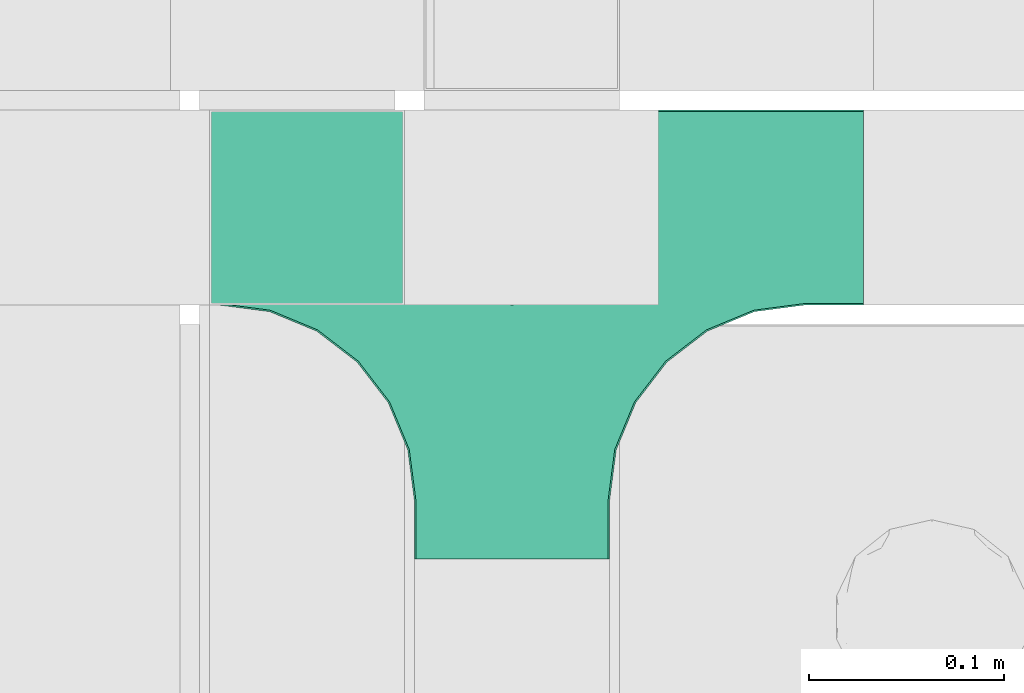
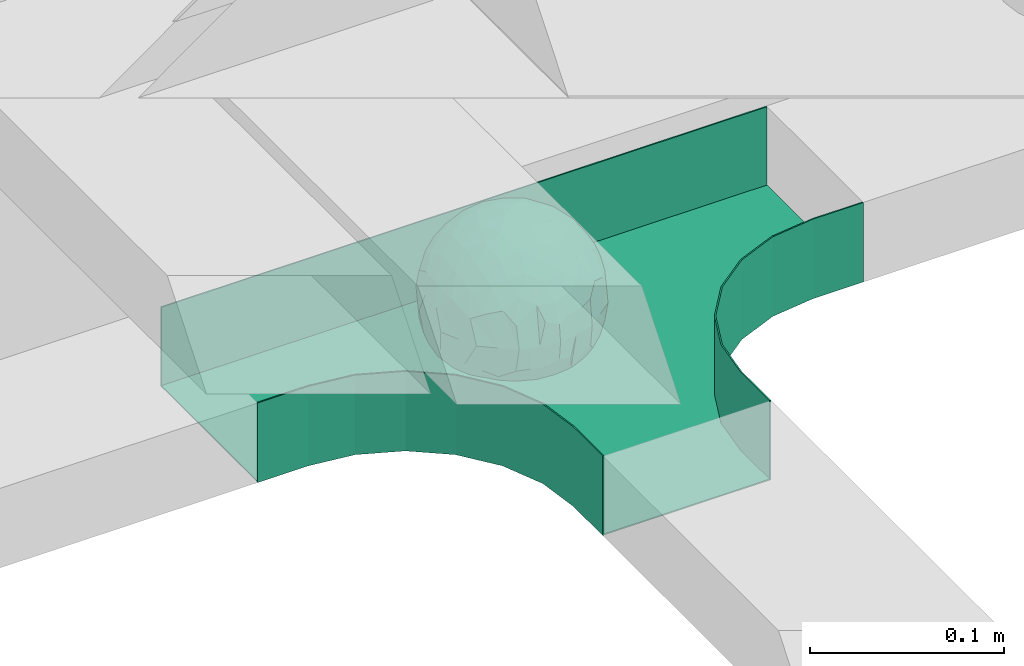
# One storey, part 28 of 33: 1 flow fitting.
"""IFC2X3 building model written with IfcOpenShell, lengths in millimetres."""

from ifc_helpers import new_model, entity, si_unit, converted_unit, derived_unit, direction, frame, origin, place, context, subcontext, project, spatial, faceted_brep, source, transform, mapped, material, material_list, type_object, type_shapes, element, save


model = new_model("IFC2X3")

# Units and contexts
model_context = context("Model", 3, precision=0.01, world=origin(), true_north=direction((6.12303176911189e-17, 1.0)))
body_context = subcontext(model_context, "Body", "Model", "MODEL_VIEW")
ifc_project = project(units=[si_unit("LENGTHUNIT", "METRE", prefix="MILLI"), si_unit("AREAUNIT", "SQUARE_METRE"), si_unit("VOLUMEUNIT", "CUBIC_METRE"), converted_unit("PLANEANGLEUNIT", "DEGREE", entity("IfcRatioMeasure", 0.0174532925199433), si_unit("PLANEANGLEUNIT", "RADIAN"), dimensions=[0, 0, 0, 0, 0, 0, 0]), si_unit("MASSUNIT", "GRAM", prefix="KILO"), derived_unit("MASSDENSITYUNIT", [(si_unit("MASSUNIT", "GRAM", prefix="KILO"), 1), (si_unit("LENGTHUNIT", "METRE"), -3)]), derived_unit("MOMENTOFINERTIAUNIT", [(si_unit("LENGTHUNIT", "METRE"), 4)]), si_unit("TIMEUNIT", "SECOND"), si_unit("FREQUENCYUNIT", "HERTZ"), si_unit("THERMODYNAMICTEMPERATUREUNIT", "DEGREE_CELSIUS"), derived_unit("THERMALTRANSMITTANCEUNIT", [(si_unit("MASSUNIT", "GRAM", prefix="KILO"), 1), (si_unit("THERMODYNAMICTEMPERATUREUNIT", "KELVIN"), -1), (si_unit("TIMEUNIT", "SECOND"), -3)]), derived_unit("VOLUMETRICFLOWRATEUNIT", [(si_unit("LENGTHUNIT", "METRE"), 3), (si_unit("TIMEUNIT", "SECOND"), -1)]), derived_unit("MASSFLOWRATEUNIT", [(si_unit("MASSUNIT", "GRAM", prefix="KILO"), 1), (si_unit("TIMEUNIT", "SECOND"), -1)]), derived_unit("ROTATIONALFREQUENCYUNIT", [(si_unit("TIMEUNIT", "SECOND"), -1)]), si_unit("ELECTRICCURRENTUNIT", "AMPERE"), si_unit("ELECTRICVOLTAGEUNIT", "VOLT"), si_unit("POWERUNIT", "WATT"), si_unit("FORCEUNIT", "NEWTON", prefix="KILO"), si_unit("ILLUMINANCEUNIT", "LUX"), si_unit("LUMINOUSFLUXUNIT", "LUMEN"), si_unit("LUMINOUSINTENSITYUNIT", "CANDELA"), derived_unit("USERDEFINED", [(si_unit("MASSUNIT", "GRAM", prefix="KILO"), -1), (si_unit("LENGTHUNIT", "METRE"), -2), (si_unit("TIMEUNIT", "SECOND"), 3), (si_unit("LUMINOUSFLUXUNIT", "LUMEN"), 1)]), derived_unit("LINEARVELOCITYUNIT", [(si_unit("LENGTHUNIT", "METRE"), 1), (si_unit("TIMEUNIT", "SECOND"), -1)]), si_unit("PRESSUREUNIT", "PASCAL"), derived_unit("USERDEFINED", [(si_unit("LENGTHUNIT", "METRE"), -2), (si_unit("MASSUNIT", "GRAM", prefix="KILO"), 1), (si_unit("TIMEUNIT", "SECOND"), -2)]), derived_unit("LINEARFORCEUNIT", [(si_unit("MASSUNIT", "GRAM", prefix="KILO"), 1), (si_unit("LENGTHUNIT", "METRE"), 1), (si_unit("TIMEUNIT", "SECOND"), -2), (si_unit("LENGTHUNIT", "METRE"), -1)]), derived_unit("PLANARFORCEUNIT", [(si_unit("MASSUNIT", "GRAM", prefix="KILO"), 1), (si_unit("LENGTHUNIT", "METRE"), 1), (si_unit("TIMEUNIT", "SECOND"), -2), (si_unit("LENGTHUNIT", "METRE"), -2)])], contexts=[model_context])

# Site, building, storey
site_placement = place(None, frame((0.0, -0.00077364408347762, 0.0)))
site = spatial("IfcSite", under=ifc_project, at=site_placement, CompositionType="ELEMENT")
building_placement = place(site_placement, origin())
building = spatial("IfcBuilding", under=site, at=building_placement, CompositionType="ELEMENT")
storey_placement = place(building_placement, frame((0.0, 0.0, 8100.0)))
storey = spatial("IfcBuildingStorey", under=building, at=storey_placement, CompositionType="ELEMENT", Elevation=8100.0)

# Flow fitting
ifc_material_1 = material()
ifc_material_2 = material()
ifc_material_list = material_list([ifc_material_1, ifc_material_2])
cable_carrier_fitting_type = type_object("IfcCableCarrierFittingType", PredefinedType="NOTDEFINED", material=ifc_material_1)
shared_shape = source(origin(), body_context, "Body", "Brep", [
    faceted_brep([(43.65414201495, -13.6159823941412, -20.221792907194), (44.7734537304832, 0.0, -22.2561865791168), (48.2627667869764, -5.5982238187369, -11.8053052540677), (16.6591030416451, 5.32882774998004, -46.8409850521773), (11.5556000970565, -8.32997143460759, -47.9278591457525), (2.01883462715812, 2.6979389970297, -49.8863250993269), (-7.81264210311725, -35.946586740035, -33.8645171988286), (-17.2052206683237, -38.2719861359275, -27.1888848422606), (-11.1277274207927, -27.3202044092451, -40.3705352142543), (37.7030088371667, -7.24923843471304, -32.0301680723234), (10.6384317789277, 26.5155476513889, -41.0335168128579), (19.2127839264957, 19.8412508508062, -41.6796556903778), (10.4192511908907, 17.8098221318595, -45.5439286870577), (48.7463956090969, 0.0, 0.0), (48.0667721403428, 6.51594663441988, -12.1296271775358), (-37.4554170352858, 12.1627069007925, -30.8084451986326), (-31.3452178059555, 12.1462454498318, -37.0127821457472), (-38.0909108580228, 3.52194087904066, -32.1974912446565), (48.7463956090969, 11.1260466978072, 0.0), (9.66670567763161, 42.5651334019307, -24.3877883338551), (17.4761229293595, 37.974251726212, -27.4324868211278), (8.3452685270067, 35.3634447252368, -34.3479733081336), (36.7018152786982, 20.4309971840494, -27.121045505536), (28.2201055605836, 12.5803931374896, -39.3110588849404), (28.3969378462537, 24.0066360557188, -33.4259681422047), (37.1036906899333, 7.75177236926259, -32.6071489449891), (30.3928805396455, 38.1114667440203, 0.0), (34.7422273315263, 34.6429784184742, 0.0), (32.9402906787036, 32.1278050479557, -19.5637775698511), (26.0435337477646, 41.5799550695664, 0.0), (-44.7734518080776, 0.0, -22.2561904464559), (-35.9183276906112, -8.71634506105637, -33.6734177755349), (-42.698067512074, -12.1858404892465, -22.9865247983333), (5.42354673897514, -48.7621108487887, 0.0), (2.92058716488888e-07, -48.7843224693665, -10.9585528791684), (7.58713024513234, -47.4313421101439, -13.8817592643935), (33.995370401777, -31.6485911362954, -18.5116576873667), (40.0066375577234, -26.2448741379086, -14.5146661281262), (30.3928805396453, -38.1114667440373, 0.0), (-47.5540080368347, -8.6499737676748, -12.798213682019), (43.918984866252, -21.1502683953847, 0.0), (-47.5463631702337, 8.67950108284767, -12.8066236860544), (-43.9189848662407, 21.1502683953677, 0.0), (-41.5587306666804, 23.544384411141, -14.7828910593852), (-36.7018137075475, 20.43099797302, -27.1210470373429), (-42.6812093094125, 12.162707383776, -23.0300438771125), (-0.0435489182880873, -44.6798423199703, -22.4434799831651), (43.3459115209922, 13.125713179152, -21.1860238825719), (-9.67158541810518, -42.815796006327, -23.9430166822217), (2.9348104480415, -38.3026865671621, -32.0045479482528), (10.5768620896568, -32.3565839798164, -36.6221444141874), (17.476122931187, -37.9742517249799, -27.4324868216925), (29.4150529887209, -14.2918330913411, -37.8219270339311), (29.2594402117981, 0.0, -40.5448536622337), (-34.742227331515, 34.6429784184742, 0.0), (-35.5934709721032, 30.8679809236437, -16.7413433706631), (16.2706402169142, 46.2863325463322, 0.0), (15.3978227309257, 45.3692296018892, -14.301750259225), (10.8470934779447, 47.524221697552, 0.0), (-22.0930685137321, 42.2576087042555, -15.0396419586498), (-16.2706402169028, 46.2863325463322, 0.0), (-15.3976096147999, 45.3685960862683, -14.3039892096614), (-35.5741674477324, -30.877857614309, -16.7641438657341), (-34.7422273315149, -34.6429784184913, 0.0), (-41.544749127214, -23.5699215759022, -14.7814957586296), (-21.2012609977656, -29.9118129495041, -33.9969113035032), (-22.0930685137892, -42.2576087036302, -15.0396419603704), (-28.5890959469058, -35.7745555449591, -20.0709932115786), (27.967317375364, -26.9235432392394, -31.5111405422078), (26.5630985649032, -36.7540375314827, -21.0604491824418), (-4.69743067705244, -12.8233951627736, -48.0988012484001), (-3.71385705669819, -22.0483048804436, -44.7222485756373), (7.046128924104e-07, -29.8515321197025, -40.1109215813634), (-8.78090686085946, 23.4705297392872, -43.266960933916), (-10.7087237416586, 12.1533783795858, -47.3034737602475), (-19.1851128431225, 19.8122800241045, -41.7061746680507), (19.2127839279743, -19.841250849511, -41.6796556903208), (10.2736167511021, -43.2535488218696, -22.8819429499797), (-16.2706402169027, -46.2863325463492, 0.0), (-15.4179487650123, -45.4307793041134, -14.0830091848577), (-10.8470934779332, -47.524221697569, 0.0), (-21.6941869558721, -45.0484433951294, 0.0), (-26.043533747753, -41.5799550695834, 0.0), (-30.3928805396339, -38.1114667440373, 0.0), (-26.9077773704145, -11.7097120961444, -40.4827637348157), (-28.5735237959864, -22.531789977659, -34.2909926698312), (-14.3485559949731, 0.554718003800719, -47.8937493708156), (20.3912706461748, 29.6966950280778, -34.6742323035854), (25.8798715159051, 35.5620355309087, -23.7817972243053), (-1.90439589452332, 38.2956374757213, -32.090768557389), (-0.0435489197807358, 44.6798423204566, -22.4434799821603), (-9.54280395759116, 42.6678856642021, -24.2566779582937), (-10.1209262269152, 33.0365306692783, -36.140759450321), (-17.2052206685055, 38.2719861378047, -27.1888848394794), (-28.5890959468196, 35.7745555453602, -20.0709932109564), (-30.3928805396341, 38.1114667440203, 0.0), (-26.0435337477532, 41.5799550695664, 0.0), (-21.6941869558723, 45.0484433951125, 0.0), (0.920553890736952, 16.9936143333855, -47.0145685125519), (7.01705705346737e-07, 29.8515321215381, -40.1109215799846), (-28.4299335912282, 23.6392950735915, -33.6589156750601), (22.0754283900311, -42.7194435884069, -13.7012627481666), (0.0, -50.0, 0.0), (-7.98433520770671, 47.2879675743241, -14.1456181900809), (-10.8470934779333, 47.524221697552, 0.0), (-5.42354673896381, 48.7621108487718, 0.0), (-39.0915741233958, -31.1744900929452, 0.0), (-36.7018137083218, -20.4309979729983, -27.1210470363242), (-20.0503020227076, 29.8835350153312, -34.7125297808217), (48.7463956090969, -11.1260466978243, 0.0), (36.7018152787698, -20.430997183803, -27.1210455056374), (39.0915741234071, -31.1744900929452, 0.0), (43.9189848662521, 21.1502683953677, 0.0), (41.0372234357161, 24.481336168204, -14.7176924857918), (21.4315363761966, -9.86715979165204, -44.0831986838696), (19.8461085062156, -30.3026908878047, -34.4656191315041), (26.0435337477644, -41.5799550695834, 0.0), (8.27678352490751, -22.6176025005053, -43.8171075221857), (-19.1851128386707, -19.8122800229913, -41.7061746706354), (-17.559283921422, -9.66340012518247, -45.8070982074481), (-29.2594384269524, -1.64502744759432e-09, -40.5448549502702), (-22.2759109836818, 8.45458562997746, -43.957977338265), (21.6941869558835, -45.0484433951294, 0.0), (-7.7537430917927, -47.3248906716555, -14.1504131029038), (22.0929359888287, 42.3611643932195, -14.7456410726513), (21.6941869558837, 45.0484433951125, 0.0), (7.94480963874029, 47.2524194975214, -14.285966940796), (5.42354673897518, 48.7621108487718, 0.0), (-43.9189848662406, -21.1502683953848, 0.0), (-39.0915741233959, 31.1744900929281, 0.0), (-48.7463956090855, 11.1260466978072, 0.0), (-48.7463956090855, -11.1260466978243, 0.0), (-48.7463956090855, 0.0, 0.0), (0.0, 50.0, 0.0), (2.95674852821199e-07, 48.76542105366, -11.0423597776141), (-5.42354673896377, -48.7621108487887, 0.0), (16.2706402169141, -46.2863325463492, 0.0), (10.8470934779446, -47.524221697569, 0.0), (39.0915741234072, 31.1744900929281, 0.0), (34.7422273315262, -34.6429784184913, 0.0), (-43.6541417785539, -13.6159824952714, 20.2217933494142), (-44.7734534735007, 0.0, 22.2561870960884), (-48.2627667188257, -5.59822380837423, 11.8053055375658), (-16.6591016552529, 5.32882757852047, 46.8409855647676), (-11.5555985538933, -8.32997141356845, 47.9278595214841), (-2.01883285210585, 2.69793886619285, 49.8863251782511), (7.81264298940045, -35.9465866899564, 33.8645170475355), (17.2052219498432, -38.2719853643866, 27.1888851173795), (11.1277291939633, -27.3202042660781, 40.370534822402), (-37.7030082707847, -7.24923849358482, 32.0301687256941), (-10.6384306361632, 26.5155474098453, 41.0335172652288), (-19.2127828542464, 19.8412506695278, 41.6796562709507), (-10.419249902145, 17.8098220464058, 45.5439290153173), (-48.0667720467311, 6.51594672713361, 12.1296274986609), (37.4554198551597, 12.1627053911885, 30.8084423663635), (31.3452204336626, 12.1462444514283, 37.0127802480704), (38.0909129847824, 3.52193921618223, 32.1974889105362), (-9.66670492251031, 42.565133342123, 24.3877887375616), (-17.4761222809685, 37.9742516795029, 27.4324872988574), (-8.34526747232003, 35.3634445391436, 34.3479737559899), (-36.7018147879525, 20.4309972885889, 27.1210460908894), (-28.2201045883605, 12.5803929822385, 39.3110596325575), (-28.3969371324566, 24.0066357536882, 33.4259689655335), (-37.1036900366786, 7.75177247673037, 32.6071496627812), (-32.9402901163369, 32.1278052689131, 19.5637781538672), (44.773453728735, 0.0, 22.2561865826485), (35.9183286182219, -8.71634518545332, 33.6734167539099), (42.6980684782056, -12.1858381773451, 22.9865242293622), (-5.1564557811304e-08, -48.7843224155168, 10.9585531189064), (-7.58712982046247, -47.4313421866568, 13.8817592350767), (-33.9953700157816, -31.6485912778883, 18.5116581541388), (-40.0066373233245, -26.2448743223541, 14.5146664406737), (47.5540088657557, -8.64997340643016, 12.7982108462298), (47.5463641063755, 8.67950029611492, 12.8066207437518), (41.5587323717035, 23.5443822102692, 14.7828897714275), (36.7018153946169, 20.4309968399072, 27.121045607934), (42.6812105193328, 12.1627054070682, 23.0300426787683), (0.0435498934198039, -44.6798421141237, 22.4434803910813), (-43.3459112327239, 13.1257132261269, 21.1860244432478), (9.6715868653752, -42.8157959611257, 23.9430161784588), (-2.93481023367521, -38.3026862522726, 32.0045483447802), (-10.5768615382775, -32.3565831315815, 36.6221453228799), (-17.4761222811971, -37.9742516793303, 27.4324872989742), (-29.4150522011614, -14.2918331221065, 37.8219276348162), (-29.259439267976, 0.0, 40.5448543433553), (35.593472529025, 30.867979902287, 16.7413419437535), (-15.3978225621776, 45.3692295068837, 14.3017507422931), (22.0930688164668, 42.2576085856364, 15.0396418472572), (15.3976099169387, 45.3685960801975, 14.3039889037045), (35.5741692798952, -30.8778564526781, 16.7641421174582), (41.5447510295928, -23.5699190140567, 14.7814944968718), (21.2012629219892, -29.9118119699372, 33.9969109653959), (22.0930688164889, -42.2576085855628, 15.039641847479), (28.5890966709526, -35.7745557157875, 20.0709918757936), (-27.9673166448933, -26.9235432178776, 31.5111412087844), (-26.5630981091642, -36.7540374223405, 21.0604499477277), (4.69743244094294, -12.8233948182002, 48.0988011680158), (3.71385918047916, -22.0483045188225, 44.7222485775695), (6.0892732202368e-07, -29.8515316280668, 40.1109219472655), (8.78090833347225, 23.4705290601204, 43.2669610034903), (10.7087255323208, 12.1533779204354, 47.3034734728551), (19.1851144535653, 19.8122792782791, 41.7061742815566), (-19.212782854423, -19.8412506693283, 41.6796562709723), (-10.2736163541564, -43.2535491498667, 22.8819425082012), (15.4179491053271, -45.430779442795, 14.0830083649343), (26.9077783310918, -11.7097109554472, 40.4827634262511), (28.5735255699879, -22.531788297607, 34.2909922955619), (14.3485579041194, 0.554717908736034, 47.893748799971), (-20.3912698186306, 29.6966949125693, 34.674232889184), (-25.8798708903081, 35.5620354347035, 23.7817980489561), (1.90439718168615, 38.2956370656312, 32.0907689704016), (0.0435498935700709, 44.6798421141929, 22.4434803909095), (9.54280511870019, 42.6678852802435, 24.2566781769111), (10.1209277017953, 33.036529901429, 36.1407597392074), (17.2052219497738, 38.2719853646937, 27.1888851169673), (28.5890966709116, 35.7745557157488, 20.0709918758907), (-0.920552500958269, 16.993613961591, 47.0145686741652), (6.09264554473049e-07, 29.8515316283504, 40.1109219470418), (28.4299352793349, 23.6392936643312, 33.6589152389788), (-22.0754282965694, -42.7194435788052, 13.7012629286858), (7.9843354212563, 47.2879674404261, 14.1456185171795), (36.7018153946056, -20.4309968401043, 27.1210456078136), (20.0503035663584, 29.8835340747136, 34.7125296989797), (-36.7018147879654, -20.4309972885437, 27.1210460909186), (-41.0372232425556, 24.4813362747081, 14.7176928472045), (-21.4315352776288, -9.8671595900376, 44.0831992630873), (-19.8461080318002, -30.3026912052829, 34.4656191255603), (-8.27678185920825, -22.617601585775, 43.8171083090061), (19.1851144530605, -19.8122792780652, 41.7061742818985), (17.5592847966676, -9.6634000411993, 45.8070978896755), (29.259440221343, 0.0, 40.5448536553604), (22.2759127990671, 8.45458631346954, 43.9579762868721), (7.75374356219277, -47.3248906381916, 14.1504129570858), (-22.0929358819219, 42.3611643749655, 14.7456412852645), (-7.94480944914509, 47.2524194744515, 14.2859671225497), (-5.23333520595152e-08, 48.7654210084985, 11.0423599770715)], [[[0, 1, 2]], [[3, 4, 5]], [[6, 7, 8]], [[1, 0, 9]], [[10, 11, 12]], [[13, 2, 14]], [[15, 16, 17]], [[14, 18, 13]], [[19, 20, 21]], [[22, 23, 24]], [[1, 9, 25]], [[26, 27, 28, 29]], [[30, 31, 32]], [[33, 34, 35]], [[36, 37, 38]], [[32, 39, 30]], [[2, 40, 0]], [[23, 22, 25]], [[41, 42, 43]], [[44, 15, 45]], [[46, 35, 34]], [[25, 22, 47]], [[31, 30, 17]], [[48, 49, 46]], [[50, 51, 49]], [[52, 53, 9]], [[43, 54, 55]], [[56, 57, 58]], [[59, 60, 61]], [[62, 63, 64]], [[8, 7, 65]], [[7, 66, 67]], [[68, 36, 69]], [[70, 5, 4]], [[8, 71, 72]], [[73, 74, 75]], [[68, 76, 52]], [[77, 46, 49]], [[78, 79, 80]], [[7, 6, 48]], [[67, 81, 82, 83]], [[84, 85, 31]], [[85, 65, 67]], [[70, 86, 5]], [[23, 3, 11]], [[21, 87, 10]], [[21, 20, 87]], [[28, 24, 88]], [[19, 89, 90]], [[91, 90, 89]], [[91, 92, 93]], [[94, 95, 96, 97]], [[98, 99, 10]], [[100, 16, 44]], [[77, 51, 101]], [[33, 102, 34]], [[103, 91, 61]], [[93, 59, 61]], [[104, 105, 103]], [[106, 64, 63]], [[107, 31, 85]], [[100, 94, 108]], [[108, 93, 92]], [[43, 55, 44]], [[0, 40, 37]], [[2, 13, 109]], [[2, 1, 14]], [[110, 9, 0]], [[2, 109, 40]], [[37, 40, 111]], [[47, 14, 1]], [[112, 14, 47]], [[113, 112, 47]], [[112, 18, 14]], [[47, 22, 113]], [[52, 9, 110]], [[53, 25, 9]], [[25, 47, 1]], [[23, 25, 53]], [[68, 52, 110]], [[76, 4, 114]], [[51, 115, 69]], [[50, 115, 51]], [[110, 36, 68]], [[3, 23, 53]], [[23, 11, 24]], [[52, 76, 114]], [[98, 12, 5]], [[11, 87, 24]], [[24, 28, 22]], [[87, 88, 24]], [[36, 116, 69]], [[28, 27, 113]], [[114, 3, 53]], [[76, 115, 117]], [[70, 4, 117]], [[118, 84, 119]], [[119, 70, 118]], [[120, 16, 121]], [[37, 36, 110]], [[116, 36, 38]], [[116, 122, 69]], [[34, 123, 46]], [[10, 87, 11]], [[87, 20, 88]], [[12, 98, 10]], [[10, 99, 21]], [[74, 5, 86]], [[73, 75, 108]], [[124, 56, 125]], [[124, 29, 88]], [[89, 21, 99]], [[21, 89, 19]], [[92, 89, 99]], [[89, 92, 91]], [[126, 127, 58]], [[88, 29, 28]], [[20, 57, 124]], [[88, 20, 124]], [[57, 20, 19]], [[73, 92, 99]], [[92, 73, 108]], [[99, 98, 73]], [[74, 86, 121]], [[73, 98, 74]], [[5, 74, 98]], [[100, 108, 75]], [[94, 93, 108]], [[86, 120, 121]], [[100, 44, 55]], [[75, 16, 100]], [[17, 16, 120]], [[31, 17, 120]], [[17, 30, 45]], [[84, 31, 120]], [[31, 107, 32]], [[41, 45, 30]], [[43, 44, 45]], [[107, 64, 32]], [[39, 64, 128]], [[30, 39, 41]], [[129, 43, 42]], [[41, 130, 42]], [[43, 45, 41]], [[62, 83, 63]], [[95, 94, 55]], [[100, 55, 94]], [[64, 107, 62]], [[131, 39, 128]], [[64, 106, 128]], [[85, 62, 107]], [[67, 83, 62]], [[39, 32, 64]], [[130, 41, 132]], [[59, 97, 60]], [[133, 127, 134]], [[59, 94, 97]], [[104, 61, 60]], [[94, 59, 93]], [[126, 134, 127]], [[126, 58, 57]], [[19, 90, 126]], [[134, 105, 133]], [[126, 90, 134]], [[103, 90, 91]], [[105, 134, 103]], [[90, 103, 134]], [[119, 120, 86]], [[84, 118, 85]], [[65, 85, 118]], [[62, 85, 67]], [[8, 65, 118]], [[67, 65, 7]], [[71, 118, 70]], [[8, 72, 6]], [[49, 6, 72]], [[6, 49, 48]], [[50, 49, 72]], [[77, 49, 51]], [[101, 69, 122]], [[123, 34, 135]], [[101, 122, 136]], [[137, 77, 136]], [[78, 81, 66]], [[7, 79, 66]], [[67, 66, 81]], [[79, 7, 48]], [[35, 137, 33]], [[123, 80, 79]], [[135, 34, 102]], [[35, 46, 77]], [[80, 123, 135]], [[46, 123, 48]], [[117, 50, 72]], [[115, 76, 68]], [[117, 72, 71]], [[4, 76, 117]], [[39, 132, 41]], [[39, 131, 132]], [[137, 35, 77]], [[124, 57, 56]], [[126, 57, 19]], [[103, 61, 104]], [[61, 91, 93]], [[77, 101, 136]], [[51, 69, 101]], [[28, 113, 22]], [[112, 113, 138]], [[16, 75, 121]], [[74, 121, 75]], [[66, 79, 78]], [[123, 79, 48]], [[0, 37, 110]], [[37, 111, 139, 38]], [[29, 124, 125]], [[115, 50, 117]], [[69, 115, 68]], [[120, 119, 84]], [[70, 119, 86]], [[11, 3, 12]], [[5, 12, 3]], [[118, 71, 8]], [[117, 71, 70]], [[3, 114, 4]], [[53, 52, 114]], [[27, 138, 113]], [[45, 15, 17]], [[44, 16, 15]], [[55, 54, 95]], [[43, 129, 54]], [[140, 141, 142]], [[143, 144, 145]], [[146, 147, 148]], [[141, 140, 149]], [[150, 151, 152]], [[132, 142, 153]], [[154, 155, 156]], [[153, 130, 132]], [[157, 158, 159]], [[160, 161, 162]], [[141, 149, 163]], [[95, 54, 164, 96]], [[165, 166, 167]], [[135, 168, 169]], [[170, 171, 83]], [[167, 172, 165]], [[142, 141, 153]], [[161, 160, 163]], [[173, 112, 174]], [[175, 154, 176]], [[177, 169, 168]], [[163, 160, 178]], [[166, 165, 156]], [[179, 180, 177]], [[181, 182, 180]], [[183, 184, 149]], [[174, 27, 185]], [[60, 186, 104]], [[187, 56, 188]], [[189, 139, 190]], [[148, 147, 191]], [[147, 192, 193]], [[194, 170, 195]], [[196, 145, 144]], [[148, 197, 198]], [[199, 200, 201]], [[194, 202, 183]], [[203, 177, 180]], [[136, 204, 137]], [[147, 146, 179]], [[193, 122, 116, 38]], [[205, 206, 166]], [[206, 191, 193]], [[196, 207, 145]], [[161, 143, 151]], [[159, 208, 150]], [[159, 158, 208]], [[164, 162, 209]], [[157, 210, 211]], [[212, 211, 210]], [[212, 213, 214]], [[215, 26, 29, 125]], [[216, 217, 150]], [[218, 155, 175]], [[203, 182, 219]], [[135, 102, 168]], [[220, 212, 188]], [[214, 187, 188]], [[58, 127, 220]], [[111, 190, 139]], [[221, 166, 206]], [[218, 215, 222]], [[222, 214, 213]], [[174, 185, 175]], [[171, 140, 128]], [[132, 131, 142]], [[142, 128, 140]], [[223, 149, 140]], [[142, 131, 128]], [[171, 128, 106]], [[178, 153, 141]], [[42, 153, 178]], [[224, 42, 178]], [[42, 130, 153]], [[178, 160, 224]], [[183, 149, 223]], [[184, 163, 149]], [[163, 178, 141]], [[161, 163, 184]], [[194, 183, 223]], [[202, 144, 225]], [[182, 226, 195]], [[181, 226, 182]], [[223, 170, 194]], [[143, 161, 184]], [[161, 151, 162]], [[183, 202, 225]], [[216, 152, 145]], [[151, 208, 162]], [[162, 164, 160]], [[208, 209, 162]], [[170, 82, 195]], [[164, 54, 224]], [[225, 143, 184]], [[202, 226, 227]], [[196, 144, 227]], [[228, 205, 229]], [[229, 196, 228]], [[230, 155, 231]], [[171, 170, 223]], [[82, 170, 83]], [[82, 81, 195]], [[168, 232, 177]], [[150, 208, 151]], [[208, 158, 209]], [[152, 216, 150]], [[150, 217, 159]], [[200, 145, 207]], [[199, 201, 222]], [[233, 60, 97]], [[233, 96, 209]], [[210, 159, 217]], [[159, 210, 157]], [[213, 210, 217]], [[210, 213, 212]], [[234, 105, 104]], [[209, 96, 164]], [[158, 186, 233]], [[209, 158, 233]], [[186, 158, 157]], [[199, 213, 217]], [[213, 199, 222]], [[217, 216, 199]], [[200, 207, 231]], [[199, 216, 200]], [[145, 200, 216]], [[218, 222, 201]], [[215, 214, 222]], [[207, 230, 231]], [[218, 175, 185]], [[201, 155, 218]], [[156, 155, 230]], [[166, 156, 230]], [[156, 165, 176]], [[205, 166, 230]], [[166, 221, 167]], [[173, 176, 165]], [[174, 175, 176]], [[221, 190, 167]], [[172, 190, 40]], [[165, 172, 173]], [[138, 174, 112]], [[173, 18, 112]], [[174, 176, 173]], [[189, 38, 139]], [[26, 215, 185]], [[218, 185, 215]], [[190, 221, 189]], [[109, 172, 40]], [[190, 111, 40]], [[206, 189, 221]], [[193, 38, 189]], [[172, 167, 190]], [[18, 173, 13]], [[187, 125, 56]], [[133, 105, 235]], [[187, 215, 125]], [[58, 188, 56]], [[215, 187, 214]], [[234, 235, 105]], [[234, 104, 186]], [[157, 211, 234]], [[235, 127, 133]], [[234, 211, 235]], [[220, 211, 212]], [[127, 235, 220]], [[211, 220, 235]], [[229, 230, 207]], [[205, 228, 206]], [[191, 206, 228]], [[189, 206, 193]], [[148, 191, 228]], [[193, 191, 147]], [[197, 228, 196]], [[148, 198, 146]], [[180, 146, 198]], [[146, 180, 179]], [[181, 180, 198]], [[203, 180, 182]], [[219, 195, 81]], [[232, 168, 33]], [[219, 81, 78]], [[80, 203, 78]], [[136, 122, 192]], [[147, 204, 192]], [[193, 192, 122]], [[204, 147, 179]], [[169, 80, 135]], [[232, 137, 204]], [[33, 168, 102]], [[169, 177, 203]], [[137, 232, 33]], [[177, 232, 179]], [[227, 181, 198]], [[226, 202, 194]], [[227, 198, 197]], [[144, 202, 227]], [[172, 13, 173]], [[172, 109, 13]], [[80, 169, 203]], [[233, 186, 60]], [[234, 186, 157]], [[220, 188, 58]], [[188, 212, 214]], [[203, 219, 78]], [[182, 195, 219]], [[164, 224, 160]], [[42, 224, 129]], [[155, 201, 231]], [[200, 231, 201]], [[192, 204, 136]], [[232, 204, 179]], [[140, 171, 223]], [[171, 106, 63, 83]], [[96, 233, 97]], [[226, 181, 227]], [[195, 226, 194]], [[230, 229, 205]], [[196, 229, 207]], [[151, 143, 152]], [[145, 152, 143]], [[228, 197, 148]], [[227, 197, 196]], [[143, 225, 144]], [[184, 183, 225]], [[54, 129, 224]], [[176, 154, 156]], [[175, 155, 154]], [[185, 27, 26]], [[174, 138, 27]]]),
    faceted_brep([(-53.4074173710859, -124.118095489752, 25.0), (-50.0, -150.0, 25.0), (-50.0, -180.0, 25.0), (-49.1999999999934, -180.0, 25.0), (-49.1999999999926, -150.0, 25.0), (-52.6346767100545, -123.91104025367, 25.0), (-62.7046392985216, -99.6000000000037, 25.0), (-78.7236364563899, -78.7236364563991, 25.0), (-99.5999999999949, -62.7046392985315, 25.0), (-123.911040253662, -52.6346767100651, 25.0), (-150.0, -49.2000000000047, 25.0), (-180.0, -49.2000000000047, 25.0), (-180.0, -50.0, 25.0), (-150.0, -50.0, 25.0), (-124.118095489745, -53.4074173710983, 25.0), (-100.0, -63.3974596215602, 25.0), (-79.2893218813398, -79.2893218813488, 25.0), (-63.3974596215496, -100.0, 25.0), (180.0, -50.0, 25.0), (180.0, -49.2000000000047, 25.0), (150.0, -49.2000000000046, 25.0), (123.911040253717, -52.634676710066, 25.0), (99.6000000000452, -62.7046392985316, 25.0), (78.7236364564342, -78.7236364563979, 25.0), (62.7046392985581, -99.6000000000012, 25.0), (52.6346767100809, -123.911040253668, 25.0), (49.200000000007, -150.0, 25.0), (49.2000000000071, -180.0, 25.0), (50.0, -180.0, 25.0), (50.0, -150.0, 25.0), (53.4074173711136, -124.11809548975, 25.0), (63.3974596215874, -100.0, 25.0), (79.2893218813853, -79.2893218813486, 25.0), (100.0, -63.3974596215613, 25.0), (124.1180954898, -53.4074173710999, 25.0), (150.0, -50.0, 25.0), (180.0, 49.1999999999958, 25.0), (180.0, 50.0, 25.0), (-180.0, 50.0, 25.0), (-180.0, 49.1999999999958, 25.0), (-180.0, -50.0, -25.0), (-180.0, 50.0, -25.0), (180.0, 50.0, -25.0), (180.0, -50.0, -25.0), (150.0, -50.0, -25.0), (124.1180954898, -53.4074173710999, -25.0), (100.0, -63.3974596215613, -25.0), (79.2893218813853, -79.2893218813486, -25.0), (63.3974596215874, -100.0, -25.0), (53.4074173711136, -124.11809548975, -25.0), (50.0, -150.0, -25.0), (50.0, -180.0, -25.0), (-50.0, -180.0, -25.0), (-50.0, -150.0, -25.0), (-53.4074173710859, -124.118095489752, -25.0), (-63.3974596215496, -100.0, -25.0), (-79.2893218813398, -79.2893218813488, -25.0), (-100.0, -63.3974596215602, -25.0), (-124.118095489745, -53.4074173710983, -25.0), (-150.0, -50.0, -25.0), (-50.0, -150.0, -24.199999999986), (49.2000000000071, -180.0, -24.199999999986), (-49.1999999999934, -180.0, -24.199999999986), (-49.1999999999926, -150.0, -24.199999999986), (-150.0, -49.2000000000047, -24.199999999986), (-180.0, -49.2000000000047, -24.199999999986), (180.0, -49.2000000000047, -24.199999999986), (150.0, -49.2000000000047, -24.199999999986), (-180.0, 49.1999999999958, -24.199999999986), (-150.0, -50.0, -24.199999999986), (150.0, -50.0, -24.199999999986), (180.0, 49.1999999999958, -24.199999999986), (49.200000000007, -150.0, -24.199999999986), (50.0, -150.0, -24.199999999986), (-123.911040253662, -52.6346767100651, -24.199999999986), (-99.5999999999949, -62.7046392985315, -24.199999999986), (-78.7236364563899, -78.7236364563991, -24.199999999986), (-62.7046392985217, -99.6000000000036, -24.199999999986), (-52.6346767100546, -123.91104025367, -24.199999999986), (52.6346767100807, -123.911040253669, -24.199999999986), (62.7046392985577, -99.6000000000018, -24.199999999986), (78.7236364564338, -78.7236364563983, -24.199999999986), (99.6000000000446, -62.704639298532, -24.199999999986), (123.911040253716, -52.6346767100662, -24.199999999986)], [[[0, 1, 2, 3, 4, 5, 6, 7, 8, 9, 10, 11, 12, 13, 14, 15, 16, 17]], [[18, 19, 20, 21, 22, 23, 24, 25, 26, 27, 28, 29, 30, 31, 32, 33, 34, 35]], [[36, 37, 38, 39]], [[40, 41, 42, 43, 44, 45, 46, 47, 48, 49, 50, 51, 52, 53, 54, 55, 56, 57, 58, 59]], [[2, 1, 60, 53, 52]], [[3, 2, 52, 51, 28, 27, 61, 62]], [[4, 3, 62, 63]], [[11, 10, 64, 65]], [[20, 19, 66, 67]], [[39, 38, 41, 40, 12, 11, 65, 68]], [[13, 12, 40, 59, 69]], [[18, 35, 70, 44, 43]], [[19, 18, 43, 42, 37, 36, 71, 66]], [[27, 26, 72, 61]], [[29, 28, 51, 50, 73]], [[38, 37, 42, 41]], [[36, 39, 68, 71]], [[68, 65, 64, 74, 75, 76, 77, 78, 63, 62, 61, 72, 79, 80, 81, 82, 83, 67, 66, 71]], [[14, 13, 69, 59, 58]], [[58, 57, 15, 14]], [[15, 57, 56, 16]], [[0, 17, 55, 54]], [[0, 54, 53, 60, 1]], [[55, 17, 16, 56]], [[5, 4, 63, 78]], [[6, 5, 78, 77]], [[7, 6, 77, 76]], [[8, 7, 76, 75]], [[9, 8, 75, 74]], [[10, 9, 74, 64]], [[21, 20, 67, 83]], [[22, 21, 83, 82]], [[23, 22, 82, 81]], [[81, 80, 24, 23]], [[24, 80, 79, 25]], [[79, 72, 26, 25]], [[30, 29, 73, 50, 49]], [[31, 30, 49, 48]], [[31, 48, 47, 32]], [[33, 32, 47, 46]], [[45, 34, 33, 46]], [[34, 45, 44, 70, 35]]]),
])
type_shapes(cable_carrier_fitting_type, [shared_shape])
flow_fitting_placement = place(storey_placement, frame((18181.0123642174, 14542.2782357463, 2590.34290576127)))
element("IfcFlowFitting", 1, at=flow_fitting_placement, inside=storey, type_object=cable_carrier_fitting_type, material=ifc_material_list, Name="470_DKC_S5_T", context=body_context, shape_type="MappedRepresentation", body=[
    mapped(shared_shape, transform((0.0, 0.0, 0.0), scale=1.0)),
])

save(model, "model.ifc")
